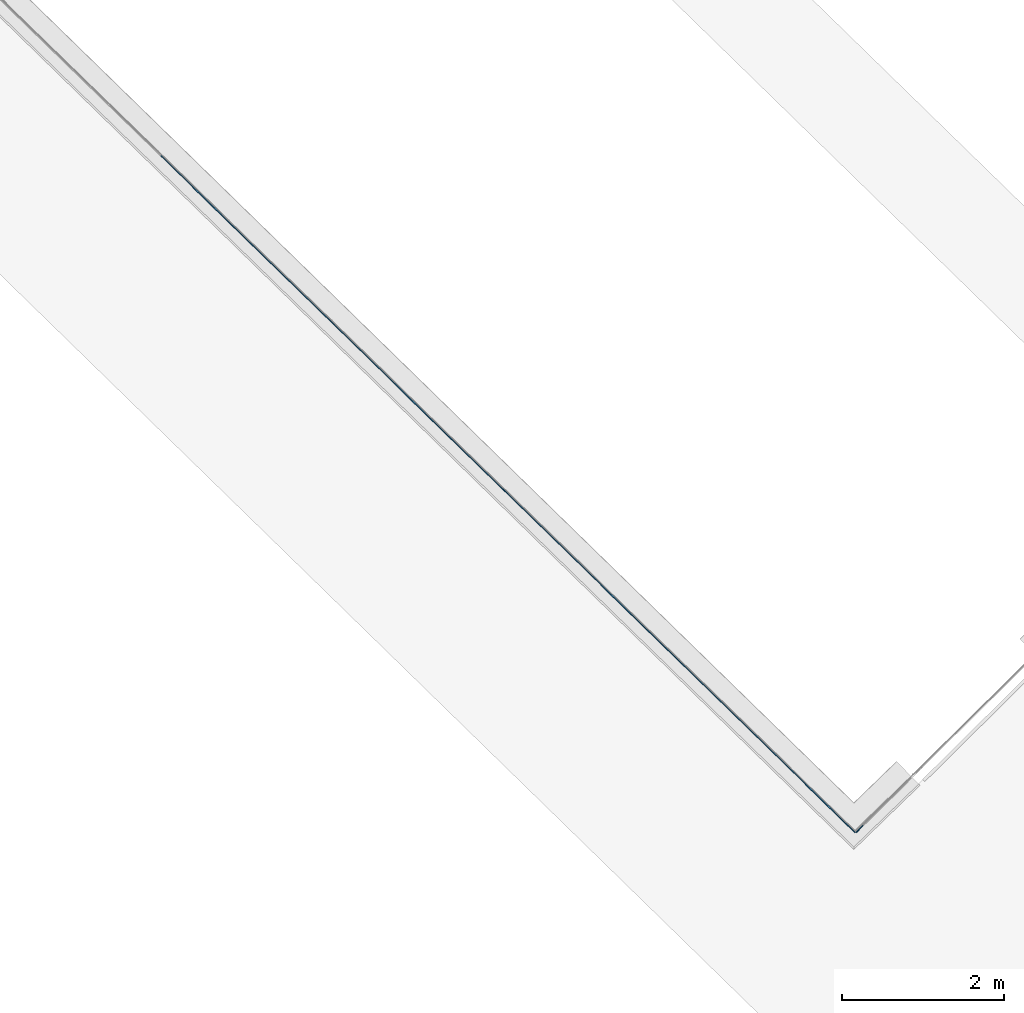
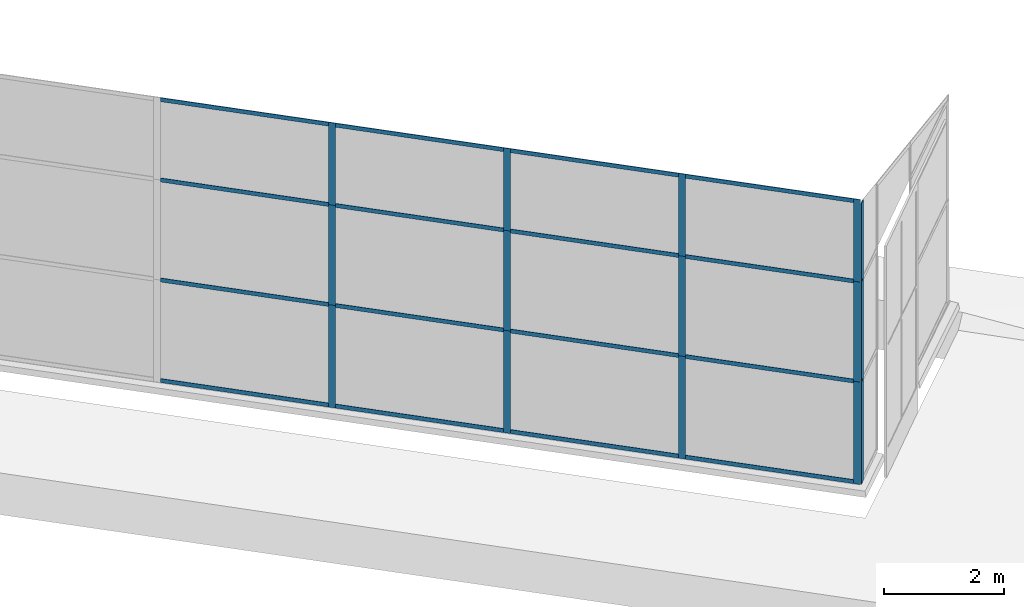
# One storey, part 2 of 13: 31 members, 2 elements without a shape of their own.
"""IFC4 building model written with IfcOpenShell, lengths in metres."""

from ifc_helpers import new_model, entity, si_unit, converted_unit, direction, frame, origin, place, context, subcontext, project, spatial, indexed_curve, outline, extrude, source, transform, mapped, material, type_object, type_shapes, element, aggregate, save


model = new_model("IFC4")

# Units and contexts
model_context = context("Model", 3, precision=1e-05, world=origin(), true_north=direction((6.123233995736766e-17, 1.0)))
body_context = subcontext(model_context, "Body", "Model", "MODEL_VIEW")
ifc_project = project(units=[si_unit("LENGTHUNIT", "METRE"), si_unit("AREAUNIT", "SQUARE_METRE"), si_unit("VOLUMEUNIT", "CUBIC_METRE"), converted_unit("PLANEANGLEUNIT", "DEGREE", entity("IfcPlaneAngleMeasure", 0.017453292519943278), si_unit("PLANEANGLEUNIT", "RADIAN"), dimensions=[0, 0, 0, 0, 0, 0, 0])], contexts=[model_context])

# Site, building, storey
site_placement = place(None, frame((0.0, 0.0, 0.0), z_axis=(0.0, 0.0, 1.0), x_axis=(0.7160934825303189, -0.6980043870045516, 0.0)))
site = spatial("IfcSite", under=ifc_project, at=site_placement, CompositionType="ELEMENT")
building_placement = place(site_placement, origin())
building = spatial("IfcBuilding", under=site, at=building_placement, CompositionType="ELEMENT")
storey_placement = place(building_placement, frame((0.0, 0.0, -7.0)))
storey = spatial("IfcBuildingStorey", under=building, at=storey_placement, Name="-7.00 m", CompositionType="ELEMENT", Elevation=-7.000000000000001)

# Curtain wall, members
curtain_wall_type_1 = type_object("IfcCurtainWallType", Name="Facciata continua:Vetrata_2", PredefinedType="NOTDEFINED")
curtain_wall_1_placement = place(storey_placement, frame((0.0, 0.0, 7.0)))
curtain_wall_1 = element("IfcCurtainWall", 1, at=curtain_wall_1_placement, inside=storey, type_object=curtain_wall_type_1, Name="Facciata continua:Vetrata_2", ObjectType="Facciata continua:Vetrata_2", PredefinedType="NOTDEFINED")
ifc_material = material(Name="Acciaio", Category="Metallo")
member_type_1 = type_object("IfcMemberType", Name="Montante rettangolare:Montante rettangolare 2", PredefinedType="MULLION", material=ifc_material)
shared_shape_1 = source(origin(), body_context, "Body", "SweptSolid", [
    extrude(outline(indexed_curve([(-0.04, -0.004999999999999997), (0.04, -0.004999999999999997), (0.04, 0.004999999999999997), (-0.04, 0.004999999999999997), (-0.04, -0.004999999999999997)], self_intersect=False)), frame((-0.04, 0.009999999999999993, -2.8811750164301526), z_axis=(0.0, 0.0, 1.0), x_axis=(-1.0, 0.0, 0.0)), (0.0, 0.0, 1.0), 2.881175016430152),
])
type_shapes(member_type_1, [shared_shape_1])
member_1_placement = place(curtain_wall_1_placement, frame((8.221964824861404, -6.977854376535891, -1.1600000000000001), z_axis=(1.0, 0.0, 0.0), x_axis=(0.0, 0.0, 1.0)))
member_1 = element("IfcMember", 2, at=member_1_placement, type_object=member_type_1, material=ifc_material, Name="Montante rettangolare:Montante rettangolare 2", ObjectType="Montante rettangolare:Montante rettangolare 2", PredefinedType="MULLION", context=body_context, shape_type="MappedRepresentation", body=[
    mapped(shared_shape_1, transform((0.0, 0.0, 0.0), scale=1.0)),
])
member_2_placement = place(curtain_wall_1_placement, frame((-0.7815602244290358, -6.977854376535862, -1.1600000000000001), z_axis=(1.0, 0.0, 0.0), x_axis=(0.0, 0.0, 1.0)))
member_2 = element("IfcMember", 3, at=member_2_placement, type_object=member_type_1, material=ifc_material, Name="Montante rettangolare:Montante rettangolare 2", ObjectType="Montante rettangolare:Montante rettangolare 2", PredefinedType="MULLION", context=body_context, shape_type="MappedRepresentation", body=[
    mapped(shared_shape_1, transform((0.0, 0.0, 0.0), scale=1.0)),
])
member_3_placement = place(curtain_wall_1_placement, frame((2.2196147920011122, -6.977854376535872, -1.1600000000000001), z_axis=(1.0, 0.0, 0.0), x_axis=(0.0, 0.0, 1.0)))
member_3 = element("IfcMember", 4, at=member_3_placement, type_object=member_type_1, material=ifc_material, Name="Montante rettangolare:Montante rettangolare 2", ObjectType="Montante rettangolare:Montante rettangolare 2", PredefinedType="MULLION", context=body_context, shape_type="MappedRepresentation", body=[
    mapped(shared_shape_1, transform((0.0, 0.0, 0.0), scale=1.0)),
])
member_4_placement = place(curtain_wall_1_placement, frame((5.220789808431251, -6.977854376535881, -1.1600000000000001), z_axis=(1.0, 0.0, 0.0), x_axis=(0.0, 0.0, 1.0)))
member_4 = element("IfcMember", 5, at=member_4_placement, type_object=member_type_1, material=ifc_material, Name="Montante rettangolare:Montante rettangolare 2", ObjectType="Montante rettangolare:Montante rettangolare 2", PredefinedType="MULLION", context=body_context, shape_type="MappedRepresentation", body=[
    mapped(shared_shape_1, transform((0.0, 0.0, 0.0), scale=1.0)),
])
member_type_2 = type_object("IfcMemberType", Name="Montante rettangolare:Montante rettangolare 2", PredefinedType="MULLION", material=ifc_material)
shared_shape_2 = source(origin(), body_context, "Body", "SweptSolid", [
    extrude(outline(indexed_curve([(-0.04, -0.004999999999999997), (0.04, -0.004999999999999997), (0.04, 0.004999999999999997), (-0.04, 0.004999999999999997), (-0.04, -0.004999999999999997)], self_intersect=False)), frame((-0.04, 0.009999999999999993, -2.8811750164301455), z_axis=(0.0, 0.0, 1.0), x_axis=(-1.0, 0.0, 0.0)), (0.0, 0.0, 1.0), 2.8811750164301437),
])
type_shapes(member_type_2, [shared_shape_2])
member_5_placement = place(curtain_wall_1_placement, frame((-3.6627352408591793, -6.977854376535852, -6.94), z_axis=(-1.0, 0.0, 0.0), x_axis=(0.0, 0.0, -1.0)))
member_5 = element("IfcMember", 6, at=member_5_placement, type_object=member_type_2, material=ifc_material, Name="Montante rettangolare:Montante rettangolare 2", ObjectType="Montante rettangolare:Montante rettangolare 2", PredefinedType="MULLION", context=body_context, shape_type="MappedRepresentation", body=[
    mapped(shared_shape_2, transform((0.0, 0.0, 0.0), scale=1.0)),
])
member_6_placement = place(curtain_wall_1_placement, frame((-0.6615602244290357, -6.977854376535862, -6.94), z_axis=(-1.0, 0.0, 0.0), x_axis=(0.0, 0.0, -1.0)))
member_6 = element("IfcMember", 7, at=member_6_placement, type_object=member_type_2, material=ifc_material, Name="Montante rettangolare:Montante rettangolare 2", ObjectType="Montante rettangolare:Montante rettangolare 2", PredefinedType="MULLION", context=body_context, shape_type="MappedRepresentation", body=[
    mapped(shared_shape_2, transform((0.0, 0.0, 0.0), scale=1.0)),
])
member_7_placement = place(curtain_wall_1_placement, frame((2.339614792001108, -6.977854376535872, -6.94), z_axis=(-1.0, 0.0, 0.0), x_axis=(0.0, 0.0, -1.0)))
member_7 = element("IfcMember", 8, at=member_7_placement, type_object=member_type_2, material=ifc_material, Name="Montante rettangolare:Montante rettangolare 2", ObjectType="Montante rettangolare:Montante rettangolare 2", PredefinedType="MULLION", context=body_context, shape_type="MappedRepresentation", body=[
    mapped(shared_shape_2, transform((0.0, 0.0, 0.0), scale=1.0)),
])
member_8_placement = place(curtain_wall_1_placement, frame((5.340789808431252, -6.977854376535881, -6.94), z_axis=(-1.0, 0.0, 0.0), x_axis=(0.0, 0.0, -1.0)))
member_8 = element("IfcMember", 9, at=member_8_placement, type_object=member_type_2, material=ifc_material, Name="Montante rettangolare:Montante rettangolare 2", ObjectType="Montante rettangolare:Montante rettangolare 2", PredefinedType="MULLION", context=body_context, shape_type="MappedRepresentation", body=[
    mapped(shared_shape_2, transform((0.0, 0.0, 0.0), scale=1.0)),
])
member_type_3 = type_object("IfcMemberType", Name="Montante rettangolare:Montante rettangolare 3", PredefinedType="MULLION", material=ifc_material)
shared_shape_3 = source(origin(), body_context, "Body", "SweptSolid", [
    extrude(outline(indexed_curve([(-0.06, -0.004999999999999997), (0.06, -0.004999999999999997), (0.06, 0.004999999999999997), (-0.06, 0.004999999999999997), (-0.06, -0.004999999999999997)], self_intersect=False)), frame((-0.06, 0.009999999999999993, -2.0800000000000005), z_axis=(0.0, 0.0, 1.0), x_axis=(-1.0, 0.0, 0.0)), (0.0, 0.0, 1.0), 2.0800000000000005),
])
type_shapes(member_type_3, [shared_shape_3])
member_9_placement = place(curtain_wall_1_placement, frame((8.341964824861403, -6.977854376535891, -6.94), z_axis=(0.0, 0.0, -1.0), x_axis=(1.0, 0.0, 0.0)))
member_9 = element("IfcMember", 10, at=member_9_placement, type_object=member_type_3, material=ifc_material, Name="Montante rettangolare:Montante rettangolare 3", ObjectType="Montante rettangolare:Montante rettangolare 3", PredefinedType="MULLION", context=body_context, shape_type="MappedRepresentation", body=[
    mapped(shared_shape_3, transform((0.0, 0.0, 0.0), scale=1.0)),
])
member_type_4 = type_object("IfcMemberType", Name="Montante rettangolare:Montante rettangolare 3", PredefinedType="MULLION", material=ifc_material)
shared_shape_4 = source(origin(), body_context, "Body", "SweptSolid", [
    extrude(outline(indexed_curve([(-0.06, -0.004999999999999997), (0.06, -0.004999999999999997), (0.06, 0.004999999999999997), (-0.06, 0.004999999999999997), (-0.06, -0.004999999999999997)], self_intersect=False)), frame((-0.06, 0.009999999999999993, -1.6699999999999993), z_axis=(0.0, 0.0, 1.0), x_axis=(-1.0, 0.0, 0.0)), (0.0, 0.0, 1.0), 1.6699999999999993),
])
type_shapes(member_type_4, [shared_shape_4])
member_10_placement = place(curtain_wall_1_placement, frame((8.3419648248614, -6.977854376535891, -2.829999999999999), z_axis=(0.0, 0.0, -1.0), x_axis=(1.0, 0.0, 0.0)))
member_10 = element("IfcMember", 11, at=member_10_placement, type_object=member_type_4, material=ifc_material, Name="Montante rettangolare:Montante rettangolare 3", ObjectType="Montante rettangolare:Montante rettangolare 3", PredefinedType="MULLION", context=body_context, shape_type="MappedRepresentation", body=[
    mapped(shared_shape_4, transform((0.0, 0.0, 0.0), scale=1.0)),
])
member_type_5 = type_object("IfcMemberType", Name="Montante rettangolare:Montante rettangolare 3", PredefinedType="MULLION", material=ifc_material)
shared_shape_5 = source(origin(), body_context, "Body", "SweptSolid", [
    extrude(outline(indexed_curve([(-0.06, -0.004999999999999997), (0.06, -0.004999999999999997), (0.06, 0.004999999999999997), (-0.06, 0.004999999999999997), (-0.06, -0.004999999999999997)], self_intersect=False)), frame((-0.06, 0.009999999999999993, -2.030000000000001), z_axis=(0.0, 0.0, 1.0), x_axis=(-1.0, 0.0, 0.0)), (0.0, 0.0, 1.0), 2.030000000000001),
])
type_shapes(member_type_5, [shared_shape_5])
member_11_placement = place(curtain_wall_1_placement, frame((8.3419648248614, -6.977854376535891, -4.86), z_axis=(0.0, 0.0, -1.0), x_axis=(1.0, 0.0, 0.0)))
member_11 = element("IfcMember", 12, at=member_11_placement, type_object=member_type_5, material=ifc_material, Name="Montante rettangolare:Montante rettangolare 3", ObjectType="Montante rettangolare:Montante rettangolare 3", PredefinedType="MULLION", context=body_context, shape_type="MappedRepresentation", body=[
    mapped(shared_shape_5, transform((0.0, 0.0, 0.0), scale=1.0)),
])

curtain_wall_type_2 = type_object("IfcCurtainWallType", Name="Facciata continua:Vetrata_1", PredefinedType="NOTDEFINED")
curtain_wall_2_placement = place(storey_placement, frame((0.0, 0.0, 7.0)))
curtain_wall_2 = element("IfcCurtainWall", 13, at=curtain_wall_2_placement, inside=storey, type_object=curtain_wall_type_2, Name="Facciata continua:Vetrata_1", ObjectType="Facciata continua:Vetrata_1", PredefinedType="NOTDEFINED")
member_type_6 = type_object("IfcMemberType", Name="Montante rettangolare:Montante rettangolare 3", PredefinedType="MULLION", material=ifc_material)
shared_shape_6 = source(origin(), body_context, "Body", "SweptSolid", [
    extrude(outline(indexed_curve([(-0.06, -0.005000000000000005), (0.06, -0.005000000000000005), (0.06, 0.005000000000000005), (-0.06, 0.005000000000000005), (-0.06, -0.005000000000000005)], self_intersect=False)), frame((-0.06, 0.010000000000000002, -2.030000000000001), z_axis=(0.0, 0.0, 1.0), x_axis=(-1.0, 0.0, 0.0)), (0.0, 0.0, 1.0), 2.030000000000001),
])
type_shapes(member_type_6, [shared_shape_6])
member_12_placement = place(curtain_wall_2_placement, frame((8.341964824861403, -6.977854376535892, -2.829999999999999), z_axis=(0.0, 0.0, 1.0), x_axis=(-0.017636182236115534, -0.9998444704433458, 0.0)))
member_12 = element("IfcMember", 14, at=member_12_placement, type_object=member_type_6, material=ifc_material, Name="Montante rettangolare:Montante rettangolare 3", ObjectType="Montante rettangolare:Montante rettangolare 3", PredefinedType="MULLION", context=body_context, shape_type="MappedRepresentation", body=[
    mapped(shared_shape_6, transform((0.0, 0.0, 0.0), scale=1.0)),
])
member_type_7 = type_object("IfcMemberType", Name="Montante rettangolare:Montante rettangolare 3", PredefinedType="MULLION", material=ifc_material)
shared_shape_7 = source(origin(), body_context, "Body", "SweptSolid", [
    extrude(outline(indexed_curve([(-0.06, -0.005000000000000005), (0.06, -0.005000000000000005), (0.06, 0.005000000000000005), (-0.06, 0.005000000000000005), (-0.06, -0.005000000000000005)], self_intersect=False)), frame((-0.06, 0.010000000000000002, -2.080000000000001), z_axis=(0.0, 0.0, 1.0), x_axis=(-1.0, 0.0, 0.0)), (0.0, 0.0, 1.0), 2.080000000000001),
])
type_shapes(member_type_7, [shared_shape_7])
member_13_placement = place(curtain_wall_2_placement, frame((8.341964824861403, -6.977854376535892, -4.86), z_axis=(0.0, 0.0, 1.0), x_axis=(-0.017636182236115534, -0.9998444704433458, 0.0)))
member_13 = element("IfcMember", 15, at=member_13_placement, type_object=member_type_7, material=ifc_material, Name="Montante rettangolare:Montante rettangolare 3", ObjectType="Montante rettangolare:Montante rettangolare 3", PredefinedType="MULLION", context=body_context, shape_type="MappedRepresentation", body=[
    mapped(shared_shape_7, transform((0.0, 0.0, 0.0), scale=1.0)),
])

# Member
member_type_8 = type_object("IfcMemberType", Name="Montante rettangolare:Montante rettangolare 2", PredefinedType="MULLION", material=ifc_material)
shared_shape_8 = source(origin(), body_context, "Body", "SweptSolid", [
    extrude(outline(indexed_curve([(-0.04, -0.005000000000000001), (0.04, -0.005000000000000001), (0.04, 0.005000000000000001), (-0.04, 0.005000000000000001), (-0.04, -0.005000000000000001)], self_intersect=False)), frame((0.0, 0.009999999999999998, -2.8811750164301433), z_axis=(0.0, 0.0, 1.0), x_axis=(-1.0, 0.0, 0.0)), (0.0, 0.0, 1.0), 2.8811750164301437),
])
type_shapes(member_type_8, [shared_shape_8])
member_14_placement = place(curtain_wall_1_placement, frame((-0.7815602244290358, -6.977854376535862, -2.829999999999999), z_axis=(1.0, 0.0, 0.0), x_axis=(0.0, 0.0, 1.0)))
member_14 = element("IfcMember", 16, at=member_14_placement, type_object=member_type_8, material=ifc_material, Name="Montante rettangolare:Montante rettangolare 2", ObjectType="Montante rettangolare:Montante rettangolare 2", PredefinedType="MULLION", context=body_context, shape_type="MappedRepresentation", body=[
    mapped(shared_shape_8, transform((0.0, 0.0, 0.0), scale=1.0)),
])

member_15_placement = place(curtain_wall_1_placement, frame((2.219614792001108, -6.977854376535872, -2.829999999999999), z_axis=(1.0, 0.0, 0.0), x_axis=(0.0, 0.0, 1.0)))
member_15 = element("IfcMember", 17, at=member_15_placement, type_object=member_type_8, material=ifc_material, Name="Montante rettangolare:Montante rettangolare 2", ObjectType="Montante rettangolare:Montante rettangolare 2", PredefinedType="MULLION", context=body_context, shape_type="MappedRepresentation", body=[
    mapped(shared_shape_8, transform((0.0, 0.0, 0.0), scale=1.0)),
])

member_16_placement = place(curtain_wall_1_placement, frame((5.220789808431251, -6.977854376535881, -2.829999999999999), z_axis=(1.0, 0.0, 0.0), x_axis=(0.0, 0.0, 1.0)))
member_16 = element("IfcMember", 18, at=member_16_placement, type_object=member_type_8, material=ifc_material, Name="Montante rettangolare:Montante rettangolare 2", ObjectType="Montante rettangolare:Montante rettangolare 2", PredefinedType="MULLION", context=body_context, shape_type="MappedRepresentation", body=[
    mapped(shared_shape_8, transform((0.0, 0.0, 0.0), scale=1.0)),
])

member_17_placement = place(curtain_wall_1_placement, frame((8.221964824861399, -6.977854376535891, -2.829999999999999), z_axis=(1.0, 0.0, 0.0), x_axis=(0.0, 0.0, 1.0)))
member_17 = element("IfcMember", 19, at=member_17_placement, type_object=member_type_8, material=ifc_material, Name="Montante rettangolare:Montante rettangolare 2", ObjectType="Montante rettangolare:Montante rettangolare 2", PredefinedType="MULLION", context=body_context, shape_type="MappedRepresentation", body=[
    mapped(shared_shape_8, transform((0.0, 0.0, 0.0), scale=1.0)),
])

member_18_placement = place(curtain_wall_1_placement, frame((-0.7815602244290358, -6.977854376535862, -4.86), z_axis=(1.0, 0.0, 0.0), x_axis=(0.0, 0.0, 1.0)))
member_18 = element("IfcMember", 20, at=member_18_placement, type_object=member_type_8, material=ifc_material, Name="Montante rettangolare:Montante rettangolare 2", ObjectType="Montante rettangolare:Montante rettangolare 2", PredefinedType="MULLION", context=body_context, shape_type="MappedRepresentation", body=[
    mapped(shared_shape_8, transform((0.0, 0.0, 0.0), scale=1.0)),
])

member_19_placement = place(curtain_wall_1_placement, frame((2.219614792001108, -6.977854376535872, -4.86), z_axis=(1.0, 0.0, 0.0), x_axis=(0.0, 0.0, 1.0)))
member_19 = element("IfcMember", 21, at=member_19_placement, type_object=member_type_8, material=ifc_material, Name="Montante rettangolare:Montante rettangolare 2", ObjectType="Montante rettangolare:Montante rettangolare 2", PredefinedType="MULLION", context=body_context, shape_type="MappedRepresentation", body=[
    mapped(shared_shape_8, transform((0.0, 0.0, 0.0), scale=1.0)),
])

member_20_placement = place(curtain_wall_1_placement, frame((5.220789808431251, -6.977854376535881, -4.86), z_axis=(1.0, 0.0, 0.0), x_axis=(0.0, 0.0, 1.0)))
member_20 = element("IfcMember", 22, at=member_20_placement, type_object=member_type_8, material=ifc_material, Name="Montante rettangolare:Montante rettangolare 2", ObjectType="Montante rettangolare:Montante rettangolare 2", PredefinedType="MULLION", context=body_context, shape_type="MappedRepresentation", body=[
    mapped(shared_shape_8, transform((0.0, 0.0, 0.0), scale=1.0)),
])

member_21_placement = place(curtain_wall_1_placement, frame((8.221964824861399, -6.977854376535891, -4.86), z_axis=(1.0, 0.0, 0.0), x_axis=(0.0, 0.0, 1.0)))
member_21 = element("IfcMember", 23, at=member_21_placement, type_object=member_type_8, material=ifc_material, Name="Montante rettangolare:Montante rettangolare 2", ObjectType="Montante rettangolare:Montante rettangolare 2", PredefinedType="MULLION", context=body_context, shape_type="MappedRepresentation", body=[
    mapped(shared_shape_8, transform((0.0, 0.0, 0.0), scale=1.0)),
])

member_type_9 = type_object("IfcMemberType", Name="Montante rettangolare:Montante rettangolare 3", PredefinedType="MULLION", material=ifc_material)
shared_shape_9 = source(origin(), body_context, "Body", "SweptSolid", [
    extrude(outline(indexed_curve([(-0.06, -0.005000000000000001), (0.06, -0.005000000000000001), (0.06, 0.005000000000000001), (-0.06, 0.005000000000000001), (-0.06, -0.005000000000000001)], self_intersect=False)), frame((0.0, 0.009999999999999998, -2.0800000000000005), z_axis=(0.0, 0.0, 1.0), x_axis=(-1.0, 0.0, 0.0)), (0.0, 0.0, 1.0), 2.0800000000000005),
])
type_shapes(member_type_9, [shared_shape_9])
member_22_placement = place(curtain_wall_1_placement, frame((-0.7215602244290358, -6.977854376535862, -6.94), z_axis=(0.0, 0.0, -1.0), x_axis=(1.0, 0.0, 0.0)))
member_22 = element("IfcMember", 24, at=member_22_placement, type_object=member_type_9, material=ifc_material, Name="Montante rettangolare:Montante rettangolare 3", ObjectType="Montante rettangolare:Montante rettangolare 3", PredefinedType="MULLION", context=body_context, shape_type="MappedRepresentation", body=[
    mapped(shared_shape_9, transform((0.0, 0.0, 0.0), scale=1.0)),
])

member_23_placement = place(curtain_wall_1_placement, frame((2.279614792001108, -6.977854376535872, -6.94), z_axis=(0.0, 0.0, -1.0), x_axis=(1.0, 0.0, 0.0)))
member_23 = element("IfcMember", 25, at=member_23_placement, type_object=member_type_9, material=ifc_material, Name="Montante rettangolare:Montante rettangolare 3", ObjectType="Montante rettangolare:Montante rettangolare 3", PredefinedType="MULLION", context=body_context, shape_type="MappedRepresentation", body=[
    mapped(shared_shape_9, transform((0.0, 0.0, 0.0), scale=1.0)),
])

member_24_placement = place(curtain_wall_1_placement, frame((5.280789808431251, -6.977854376535881, -6.94), z_axis=(0.0, 0.0, -1.0), x_axis=(1.0, 0.0, 0.0)))
member_24 = element("IfcMember", 26, at=member_24_placement, type_object=member_type_9, material=ifc_material, Name="Montante rettangolare:Montante rettangolare 3", ObjectType="Montante rettangolare:Montante rettangolare 3", PredefinedType="MULLION", context=body_context, shape_type="MappedRepresentation", body=[
    mapped(shared_shape_9, transform((0.0, 0.0, 0.0), scale=1.0)),
])

member_type_10 = type_object("IfcMemberType", Name="Montante rettangolare:Montante rettangolare 3", PredefinedType="MULLION", material=ifc_material)
shared_shape_10 = source(origin(), body_context, "Body", "SweptSolid", [
    extrude(outline(indexed_curve([(-0.06, -0.005000000000000001), (0.06, -0.005000000000000001), (0.06, 0.005000000000000001), (-0.06, 0.005000000000000001), (-0.06, -0.005000000000000001)], self_intersect=False)), frame((0.0, 0.009999999999999998, -1.6699999999999993), z_axis=(0.0, 0.0, 1.0), x_axis=(-1.0, 0.0, 0.0)), (0.0, 0.0, 1.0), 1.6699999999999993),
])
type_shapes(member_type_10, [shared_shape_10])
member_25_placement = place(curtain_wall_1_placement, frame((-0.7215602244290358, -6.977854376535862, -2.829999999999999), z_axis=(0.0, 0.0, -1.0), x_axis=(1.0, 0.0, 0.0)))
member_25 = element("IfcMember", 27, at=member_25_placement, type_object=member_type_10, material=ifc_material, Name="Montante rettangolare:Montante rettangolare 3", ObjectType="Montante rettangolare:Montante rettangolare 3", PredefinedType="MULLION", context=body_context, shape_type="MappedRepresentation", body=[
    mapped(shared_shape_10, transform((0.0, 0.0, 0.0), scale=1.0)),
])

member_26_placement = place(curtain_wall_1_placement, frame((2.279614792001108, -6.977854376535872, -2.829999999999999), z_axis=(0.0, 0.0, -1.0), x_axis=(1.0, 0.0, 0.0)))
member_26 = element("IfcMember", 28, at=member_26_placement, type_object=member_type_10, material=ifc_material, Name="Montante rettangolare:Montante rettangolare 3", ObjectType="Montante rettangolare:Montante rettangolare 3", PredefinedType="MULLION", context=body_context, shape_type="MappedRepresentation", body=[
    mapped(shared_shape_10, transform((0.0, 0.0, 0.0), scale=1.0)),
])

member_27_placement = place(curtain_wall_1_placement, frame((5.280789808431251, -6.977854376535881, -2.829999999999999), z_axis=(0.0, 0.0, -1.0), x_axis=(1.0, 0.0, 0.0)))
member_27 = element("IfcMember", 29, at=member_27_placement, type_object=member_type_10, material=ifc_material, Name="Montante rettangolare:Montante rettangolare 3", ObjectType="Montante rettangolare:Montante rettangolare 3", PredefinedType="MULLION", context=body_context, shape_type="MappedRepresentation", body=[
    mapped(shared_shape_10, transform((0.0, 0.0, 0.0), scale=1.0)),
])

member_type_11 = type_object("IfcMemberType", Name="Montante rettangolare:Montante rettangolare 3", PredefinedType="MULLION", material=ifc_material)
shared_shape_11 = source(origin(), body_context, "Body", "SweptSolid", [
    extrude(outline(indexed_curve([(-0.06, -0.005000000000000001), (0.06, -0.005000000000000001), (0.06, 0.005000000000000001), (-0.06, 0.005000000000000001), (-0.06, -0.005000000000000001)], self_intersect=False)), frame((0.0, 0.009999999999999998, -2.030000000000001), z_axis=(0.0, 0.0, 1.0), x_axis=(-1.0, 0.0, 0.0)), (0.0, 0.0, 1.0), 2.030000000000001),
])
type_shapes(member_type_11, [shared_shape_11])
member_28_placement = place(curtain_wall_1_placement, frame((-0.7215602244290358, -6.977854376535862, -4.86), z_axis=(0.0, 0.0, -1.0), x_axis=(1.0, 0.0, 0.0)))
member_28 = element("IfcMember", 30, at=member_28_placement, type_object=member_type_11, material=ifc_material, Name="Montante rettangolare:Montante rettangolare 3", ObjectType="Montante rettangolare:Montante rettangolare 3", PredefinedType="MULLION", context=body_context, shape_type="MappedRepresentation", body=[
    mapped(shared_shape_11, transform((0.0, 0.0, 0.0), scale=1.0)),
])

member_29_placement = place(curtain_wall_1_placement, frame((2.279614792001108, -6.977854376535872, -4.86), z_axis=(0.0, 0.0, -1.0), x_axis=(1.0, 0.0, 0.0)))
member_29 = element("IfcMember", 31, at=member_29_placement, type_object=member_type_11, material=ifc_material, Name="Montante rettangolare:Montante rettangolare 3", ObjectType="Montante rettangolare:Montante rettangolare 3", PredefinedType="MULLION", context=body_context, shape_type="MappedRepresentation", body=[
    mapped(shared_shape_11, transform((0.0, 0.0, 0.0), scale=1.0)),
])

member_30_placement = place(curtain_wall_1_placement, frame((5.280789808431251, -6.977854376535881, -4.86), z_axis=(0.0, 0.0, -1.0), x_axis=(1.0, 0.0, 0.0)))
member_30 = element("IfcMember", 32, at=member_30_placement, type_object=member_type_11, material=ifc_material, Name="Montante rettangolare:Montante rettangolare 3", ObjectType="Montante rettangolare:Montante rettangolare 3", PredefinedType="MULLION", context=body_context, shape_type="MappedRepresentation", body=[
    mapped(shared_shape_11, transform((0.0, 0.0, 0.0), scale=1.0)),
])

aggregate(curtain_wall_1, [member_1, member_2, member_3, member_4, member_5, member_6, member_7, member_8, member_9, member_10, member_11, member_14, member_15, member_16, member_17, member_18, member_19, member_20, member_21, member_22, member_23, member_24, member_25, member_26, member_27, member_28, member_29, member_30])

member_type_12 = type_object("IfcMemberType", Name="Montante rettangolare:Montante rettangolare 3", PredefinedType="MULLION", material=ifc_material)
shared_shape_12 = source(origin(), body_context, "Body", "SweptSolid", [
    extrude(outline(indexed_curve([(-0.06, -0.005000000000000005), (0.06, -0.005000000000000005), (0.06, 0.005000000000000005), (-0.06, 0.005000000000000005), (-0.06, -0.005000000000000005)], self_intersect=False)), frame((-0.06, 0.010000000000000002, -1.5900000000000003), z_axis=(0.0, 0.0, 1.0), x_axis=(-1.0, 0.0, 0.0)), (0.0, 0.0, 1.0), 1.5900000000000003),
])
type_shapes(member_type_12, [shared_shape_12])
member_31_placement = place(curtain_wall_2_placement, frame((8.341964824861403, -6.977854376535892, -1.2399999999999993), z_axis=(0.0, 0.0, 1.0), x_axis=(-0.017636182236115534, -0.9998444704433458, 0.0)))
member_31 = element("IfcMember", 33, at=member_31_placement, type_object=member_type_12, material=ifc_material, Name="Montante rettangolare:Montante rettangolare 3", ObjectType="Montante rettangolare:Montante rettangolare 3", PredefinedType="MULLION", context=body_context, shape_type="MappedRepresentation", body=[
    mapped(shared_shape_12, transform((0.0, 0.0, 0.0), scale=1.0)),
])

aggregate(curtain_wall_2, [member_31, member_12, member_13])

save(model, "model.ifc")
